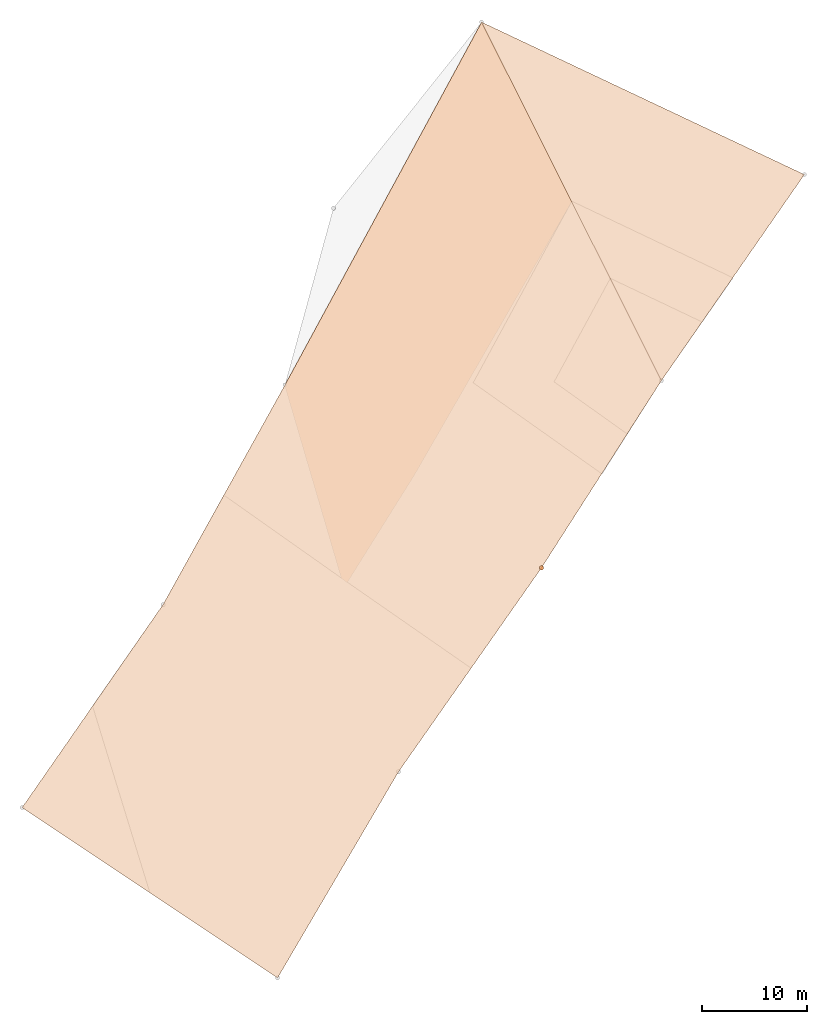
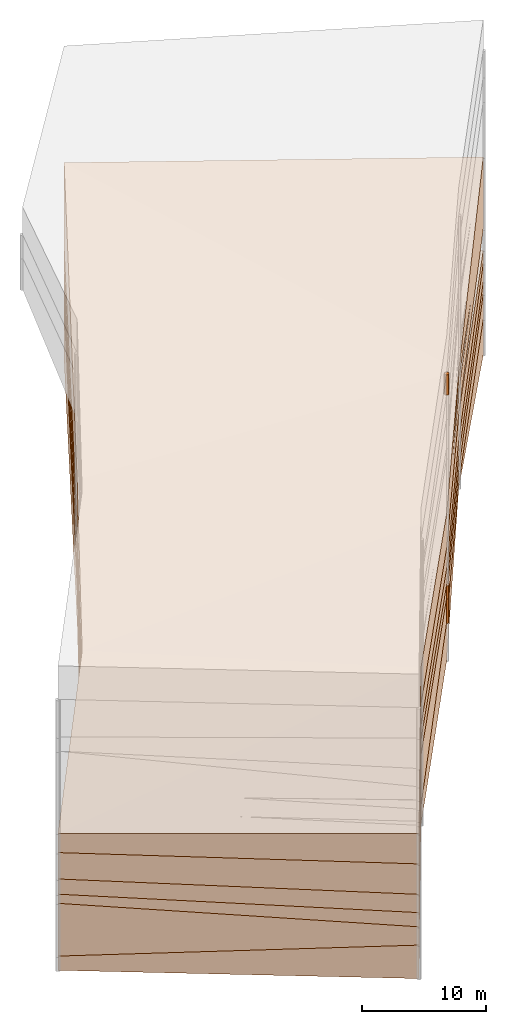
# One storey, part 12 of 24: 9 geographic elements.
"""IFC4 building model written with IfcOpenShell, lengths in metres."""

from ifc_helpers import new_model, entity, si_unit, converted_unit, frame, origin_with_axes, origin_2d_with_axis, place, context, subcontext, project, spatial, polygons, element, save


model = new_model("IFC4")

# Units and contexts
model_context = context("Model", 3, precision=1e-05, world=origin_with_axes())
plan_context = context("Plan", 2, precision=1e-05, world=origin_2d_with_axis())
body_context = subcontext(model_context, "Body", "Model", "MODEL_VIEW")
ifc_project = project(units=[converted_unit("PLANEANGLEUNIT", "degree", entity("IfcReal", 0.0174532925199433), si_unit("PLANEANGLEUNIT", "RADIAN"), dimensions=[0, 0, 0, 0, 0, 0, 0]), si_unit("AREAUNIT", "SQUARE_METRE"), si_unit("VOLUMEUNIT", "CUBIC_METRE"), si_unit("LENGTHUNIT", "METRE")], contexts=[model_context, plan_context])

# Site, building, storey
site_placement = place(None, origin_with_axes())
site = spatial("IfcSite", under=ifc_project, at=site_placement)
building_placement = place(site_placement, origin_with_axes())
building = spatial("IfcBuilding", under=site, at=building_placement, Name="Building")
storey_placement = place(building_placement, origin_with_axes())
storey = spatial("IfcBuildingStorey", under=building, at=storey_placement, Name="Storey")

# Geographic elements
geographic_element_1_placement = place(storey_placement, frame((7.95133209228516, 42.8018035888672, 0.786202132701874), z_axis=(0.0, 0.0, 1.0), x_axis=(0.830287629604424, -0.557335134480025, 0.0)))
element("IfcGeographicElement", 1, at=geographic_element_1_placement, inside=storey, PredefinedType="NOTDEFINED", context=body_context, shape_type="Tessellation", body=[
    polygons([(-17.3011207580566, 46.3160743713379, -1.78619968891144), (16.2700653076172, 51.3870964050293, -1.88620126247406), (16.2700634002686, 51.3870964050293, 5.21379899978638), (17.2530536651611, -39.969367980957, -0.586199462413788), (15.8775949478149, -17.2863731384277, -0.78620308637619), (17.2530498504639, -39.9693641662598, 2.41380023956299), (-11.9517650604248, -40.0619468688965, -0.786202311515808), (-11.9517660140991, -40.0619468688965, 1.11379766464233), (-11.5824747085571, -16.5691032409668, -0.686202526092529), (15.877592086792, -17.2863731384277, 2.81379675865173), (16.3572044372559, 6.40096139907837, 1.51979982852936), (-11.5824756622314, -16.5691032409668, 2.71379733085632), (16.3572044372559, 6.40096235275269, -1.88020026683807), (-13.599440574646, 7.2489914894104, -1.5772031545639), (15.9019184112549, 27.5337047576904, -3.48620200157166), (15.9019212722778, 27.5336990356445, 0.813797891139984), (15.901930809021, 27.5332012176514, -1.28617215156555), (16.128360748291, 17.0230274200439, -0.656133651733398), (16.1270484924316, 17.0840301513672, -0.656139612197876), (-13.5994424819946, 7.24899053573608, 2.82079696655273), (-17.3011226654053, 46.3160820007324, 6.61379957199097), (16.0857696533203, 39.4459991455078, -0.636202096939087), (15.9019355773926, 27.5346412658691, 0.0137467021122575), (15.901930809021, 27.5343894958496, -1.28616452217102), (15.9019174575806, 27.5337009429932, 0.0137979974970222), (15.9019174575806, 27.5337009429932, -1.28620207309723), (15.9019355773926, 27.5330333709717, 0.0137553941458464), (1.15123677253723, 17.3913478851318, -0.636202096939087), (-0.685844838619232, 36.9582176208496, -0.636202096939087)], [[[4, 8, 7]], [[12, 20, 14, 9]], [[8, 12, 9, 7]], [[24, 26, 25, 23]], [[11, 12, 10]], [[17, 28, 19]], [[8, 10, 12]], [[20, 1, 14]], [[11, 5, 13]], [[15, 16, 17]], [[18, 15, 19]], [[21, 16, 3]], [[16, 20, 11]], [[1, 3, 2]], [[25, 29, 23]], [[1, 2, 15]], [[2, 22, 15]], [[16, 15, 24]], [[16, 24, 23]], [[5, 7, 9]], [[13, 9, 14]], [[15, 14, 1]], [[28, 25, 27]], [[29, 22, 23]], [[29, 26, 24]], [[29, 24, 22]], [[26, 17, 27, 25]], [[17, 16, 27]], [[16, 18, 27]], [[16, 11, 18]], [[18, 11, 13]], [[15, 18, 13]], [[17, 19, 15]], [[22, 24, 15]], [[3, 22, 2]], [[3, 16, 22]], [[22, 16, 23]], [[26, 29, 17]], [[19, 28, 18]], [[28, 27, 18]], [[6, 5, 10]], [[4, 6, 8]], [[11, 20, 12]], [[17, 29, 28]], [[8, 6, 10]], [[20, 21, 1]], [[11, 10, 5]], [[21, 20, 16]], [[1, 21, 3]], [[25, 28, 29]], [[5, 4, 7]], [[13, 5, 9]], [[15, 13, 14]], [[6, 4, 5]]]),
])
geographic_element_2_placement = place(storey_placement, frame((22.7823867797852, 60.1952819824219, -5.6460132598877), z_axis=(0.0, 0.0, 1.0), x_axis=(0.867209961126124, -0.497942650637226, 0.0)))
element("IfcGeographicElement", 2, at=geographic_element_2_placement, inside=storey, PredefinedType="NOTDEFINED", context=body_context, shape_type="Tessellation", body=[
    polygons([(-18.2224273681641, 24.9432010650635, -1.05398368835449), (15.6210842132568, 27.65549659729, -1.8539856672287), (15.6210823059082, 27.65549659729, -0.653985977172852), (10.2166843414307, -63.5462646484375, -0.353983849287033), (10.4299249649048, -40.8226127624512, 0.646012187004089), (10.4299240112305, -40.8226089477539, 2.14601230621338), (10.2166843414307, -63.5462646484375, 1.04601562023163), (-18.9231872558594, -61.5974655151367, 0.646013259887695), (-16.9128646850586, -38.1878852844238, 0.546012759208679), (-18.9231872558594, -61.597469329834, 1.54601275920868), (13.586706161499, 3.88616228103638, -1.15398633480072), (-18.2224292755127, 24.9432048797607, 0.546015799045563), (-17.2602348327637, -14.2870655059814, 0.159011766314507), (12.5638914108276, -17.2267208099365, 0.952014684677124), (-16.9128665924072, -38.1878852844238, 2.04601263999939), (-17.260232925415, -14.2870674133301, -1.34398889541626), (13.5867052078247, 3.88616251945496, -2.5539870262146), (12.563892364502, -17.2267189025879, -0.34798526763916)], [[[14, 6, 5, 18]], [[10, 6, 15]], [[1, 12, 3, 2]], [[15, 14, 13]], [[5, 8, 9]], [[15, 13, 16, 9]], [[13, 11, 12]], [[1, 17, 16]], [[7, 5, 6]], [[11, 2, 3]], [[9, 18, 5]], [[7, 8, 4]], [[10, 9, 8]], [[18, 11, 14]], [[13, 1, 16]], [[10, 7, 6]], [[15, 6, 14]], [[5, 4, 8]], [[13, 14, 11]], [[1, 2, 17]], [[7, 4, 5]], [[11, 17, 2]], [[9, 16, 18]], [[7, 10, 8]], [[10, 15, 9]], [[18, 17, 11]], [[13, 12, 1]]]),
])
geographic_element_3_placement = place(storey_placement, frame((10.1280975341797, 43.8058166503906, -1.91961908340454), z_axis=(0.0, 0.0, 1.0), x_axis=(0.762361207972851, -0.647151750811335, 0.0)))
element("IfcGeographicElement", 3, at=geographic_element_3_placement, inside=storey, PredefinedType="NOTDEFINED", context=body_context, shape_type="Tessellation", body=[
    polygons([(-23.4085464477539, 41.9031105041504, -3.18037819862366), (9.37964344024658, 50.716423034668, -4.38037967681885), (9.37964057922363, 50.716423034668, -2.58037996292114), (20.627742767334, -39.950267791748, -2.68037819862366), (16.7107181549072, -17.5657424926758, -1.58038175106049), (16.7107181549072, -17.565746307373, -0.180381760001183), (20.627742767334, -39.950267791748, -0.880378186702728), (-8.38149642944336, -43.3258018493652, -2.18038105964661), (-10.6558847427368, -19.9403991699219, -1.68038141727448), (-8.38149452209473, -43.3258056640625, -0.680381059646606), (11.695707321167, 26.97287940979, -3.38038039207458), (14.5240888595581, 6.02532434463501, -1.17437899112701), (-10.6558799743652, -19.9404010772705, 0.119618646800518), (-15.337963104248, 3.49990677833557, -3.56738209724426), (14.5240879058838, 6.02532434463501, -2.77437925338745), (-15.3379621505737, 3.49990725517273, -0.969382345676422), (11.6957035064697, 26.97287940979, -4.88038015365601), (-23.4085426330566, 41.9031028747559, -1.38037848472595)], [[[6, 7, 4, 5]], [[10, 6, 13]], [[11, 2, 3]], [[13, 12, 16]], [[12, 6, 5, 15]], [[16, 12, 11]], [[16, 9, 13]], [[14, 17, 15]], [[15, 11, 12]], [[5, 8, 9]], [[1, 3, 2]], [[15, 9, 14]], [[17, 14, 1]], [[18, 11, 3]], [[11, 18, 16]], [[7, 8, 4]], [[10, 9, 8]], [[18, 14, 16]], [[10, 7, 6]], [[11, 17, 2]], [[13, 6, 12]], [[16, 14, 9]], [[15, 17, 11]], [[5, 4, 8]], [[1, 18, 3]], [[15, 5, 9]], [[7, 10, 8]], [[10, 13, 9]], [[18, 1, 14]]]),
])
geographic_element_4_placement = place(storey_placement, frame((10.1280975341797, 43.8058166503906, -1.91961908340454), z_axis=(0.0, 0.0, 1.0), x_axis=(0.836836988464579, -0.547452148354114, 0.0)))
element("IfcGeographicElement", 4, at=geographic_element_4_placement, inside=storey, PredefinedType="NOTDEFINED", context=body_context, shape_type="Tessellation", body=[
    polygons([(-18.022741317749, 44.4860763549805, -1.38037836551666), (15.6062059402466, 49.1587181091309, -2.58037996292114), (15.6062097549438, 49.1587219238281, -1.28037989139557), (15.5060205459595, -42.2029724121094, -0.880378186702728), (14.3995838165283, -19.5052700042725, -0.180381760001183), (14.3995847702026, -19.5052719116211, 1.91961801052094), (15.5060224533081, -42.2029762268066, 2.11962151527405), (-13.6978406906128, -41.9493026733398, -0.680381059646606), (-13.0500526428223, -18.4624881744385, 0.119618646800518), (-13.6978397369385, -41.9493026733398, 1.91961872577667), (14.9552879333496, 25.3113651275635, -0.78038078546524), (-18.0227375030518, 44.4860725402832, 0.919621407985687), (15.1599960327148, 4.17471504211426, 0.825620830059052), (-14.7844924926758, 5.37784433364868, 1.12861788272858), (-13.0500516891479, -18.4624881744385, 2.01961874961853), (14.9552879333496, 25.3113651275635, -3.38038039207458), (-14.7844915390015, 5.37784481048584, -0.969382226467133), (15.1599969863892, 4.17471504211426, -1.17437899112701)], [[[10, 6, 15]], [[11, 2, 3]], [[12, 17, 14]], [[1, 3, 2]], [[9, 18, 5]], [[16, 1, 2]], [[14, 13, 11]], [[11, 13, 18, 16]], [[17, 16, 18]], [[14, 17, 9, 15]], [[12, 11, 3]], [[5, 8, 9]], [[6, 7, 4, 5]], [[13, 5, 18]], [[10, 15, 9, 8]], [[15, 13, 14]], [[10, 4, 7]], [[10, 7, 6]], [[11, 16, 2]], [[12, 1, 17]], [[1, 12, 3]], [[9, 17, 18]], [[16, 17, 1]], [[12, 14, 11]], [[5, 4, 8]], [[13, 6, 5]], [[15, 6, 13]], [[10, 8, 4]]]),
])
geographic_element_5_placement = place(storey_placement, frame((25.6226844787598, 67.0861511230469, -8.31018447875977), z_axis=(0.0, 0.0, 1.0), x_axis=(0.826104281963329, -0.563517271538196, 0.0)))
element("IfcGeographicElement", 5, at=geographic_element_5_placement, inside=storey, PredefinedType="NOTDEFINED", context=body_context, shape_type="Tessellation", body=[
    polygons([(-18.5601062774658, 16.1661338806152, 1.610187292099), (14.9722986221313, 21.4876003265381, -1.68981444835663), (16.6371936798096, -69.8589859008789, 0.510187566280365), (15.0924549102783, -47.1868858337402, -1.68981659412384), (15.0924558639526, -47.1868858337402, 3.31018328666687), (16.6371936798096, -69.8589782714844, 2.31018733978271), (-12.5661153793335, -70.169563293457, -1.88981521129608), (-12.5661172866821, -70.169563293457, 3.31018424034119), (-12.3722009658813, -46.6746139526367, -0.589816212654114), (15.3952388763428, -23.4966297149658, 2.31618595123291), (-12.3722019195557, -46.6746139526367, 3.21018362045288), (15.3952388763428, -23.4966297149658, -0.0838150903582573), (-14.5669059753418, -22.8722343444824, 1.32018172740936), (14.7822170257568, -2.36787891387939, 0.110183626413345), (14.7822170257568, -2.36787915229797, -1.18981528282166), (14.9722967147827, 21.4875984191895, 0.810185372829437)], [[[8, 5, 11]], [[9, 12, 4]], [[14, 10, 12, 15]], [[4, 7, 9]], [[3, 8, 7]], [[10, 5, 4, 12]], [[11, 10, 13]], [[13, 15, 12]], [[13, 10, 14]], [[8, 9, 7]], [[1, 13, 14]], [[15, 13, 1]], [[2, 1, 16]], [[5, 6, 3, 4]], [[11, 13, 9]], [[14, 2, 16]], [[8, 6, 5]], [[9, 13, 12]], [[4, 3, 7]], [[3, 6, 8]], [[11, 5, 10]], [[8, 11, 9]], [[14, 15, 2]]]),
])
geographic_element_6_placement = place(storey_placement, frame((0.941490471363068, 18.3487815856934, 0.146752789616585), z_axis=(1.20677100312604e-07, 2.68795723457058e-08, 0.999999999999992), x_axis=(0.843925976962061, -0.536459640055637, -8.74227364323347e-08)))
element("IfcGeographicElement", 6, at=geographic_element_6_placement, inside=storey, PredefinedType="NOTDEFINED", context=body_context, shape_type="Tessellation", body=[
    polygons([(-23.3431797027588, 71.1300964355469, -12.2467432022095), (-23.3431797027588, 71.1300964355469, -6.84674501419067), (10.3440017700195, 75.3624801635742, -13.6467428207397), (10.3440074920654, 75.3624801635742, -10.1467428207397), (9.04883098602295, -15.9900808334351, -11.2467489242554), (8.23937225341797, 6.72014999389648, -12.0467510223389), (8.23937225341797, 6.72014999389648, -10.1467523574829), (9.04883003234863, -15.9900817871094, -7.94675016403198), (-20.1492080688477, -15.3544483184814, -11.746753692627), (-20.1492080688477, -15.3544464111328, -10.346755027771), (-19.1942710876465, 8.12187671661377, -12.1467542648315), (9.38122081756592, 51.5256767272949, -10.1467456817627), (-19.1942710876465, 8.12187576293945, -9.0467529296875), (-20.6167411804199, 31.9828605651855, -10.7367534637451), (9.30944919586182, 30.388162612915, -8.54074668884277), (-20.6167449951172, 31.9828586578369, -7.13675355911255), (9.30944919586182, 30.3881607055664, -12.3407459259033), (9.38122272491455, 51.5256767272949, -9.6467456817627)], [[[13, 14, 11]], [[13, 15, 16]], [[6, 9, 11]], [[7, 8, 5, 6]], [[1, 12, 14]], [[17, 11, 14]], [[10, 13, 11, 9]], [[15, 12, 18]], [[16, 15, 18]], [[4, 12, 3]], [[15, 7, 6, 17]], [[1, 4, 3]], [[10, 7, 13]], [[5, 10, 9]], [[2, 16, 18]], [[14, 12, 17]], [[2, 14, 16]], [[13, 16, 14]], [[13, 7, 15]], [[6, 5, 9]], [[1, 3, 12]], [[17, 6, 11]], [[15, 17, 12]], [[4, 18, 12]], [[1, 2, 4]], [[10, 8, 7]], [[5, 8, 10]], [[2, 1, 14]]]),
])
geographic_element_7_placement = place(storey_placement, frame((25.1000003814697, 39.0, 15.1000003814697), z_axis=(0.0, 0.0, 1.0), x_axis=(1.0, 0.0, 0.0)))
element("IfcGeographicElement", 7, at=geographic_element_7_placement, inside=storey, PredefinedType="NOTDEFINED", context=body_context, shape_type="Tessellation", body=[
    polygons([(0.0, 0.0, -1.00000023841858), (0.0390180610120296, 0.196157038211823, -1.00000023841858), (0.0, 0.199999988079071, -1.00000023841858), (0.0, 0.0, 1.00000023841858), (0.0, 0.199999988079071, 1.00000023841858), (0.0390180610120296, 0.196157038211823, 1.00000023841858), (0.0765366926789284, 0.18477588891983, -1.00000023841858), (0.0765366926789284, 0.18477588891983, 1.00000023841858), (0.111114047467709, 0.166293919086456, -1.00000023841858), (0.111114047467709, 0.166293919086456, 1.00000023841858), (0.141421362757683, 0.141421362757683, -1.00000023841858), (0.141421362757683, 0.141421362757683, 1.00000023841858), (0.166293919086456, 0.111114047467709, -1.00000023841858), (0.166293919086456, 0.111114047467709, 1.00000023841858), (0.18477588891983, 0.0765366926789284, -1.00000023841858), (0.18477588891983, 0.0765366926789284, 1.00000023841858), (0.196157038211823, 0.0390180610120296, -1.00000023841858), (0.196157038211823, 0.0390180610120296, 1.00000023841858), (0.199999988079071, 0.0, -1.00000023841858), (0.199999988079071, 0.0, 1.00000023841858), (0.196157038211823, -0.0390180610120296, -1.00000023841858), (0.196157038211823, -0.0390180610120296, 1.00000023841858), (0.18477588891983, -0.0765366926789284, -1.00000023841858), (0.18477588891983, -0.0765366926789284, 1.00000023841858), (0.166293919086456, -0.111114047467709, -1.00000023841858), (0.166293919086456, -0.111114047467709, 1.00000023841858), (0.141421362757683, -0.141421362757683, -1.00000023841858), (0.141421362757683, -0.141421362757683, 1.00000023841858), (0.111114047467709, -0.166293919086456, -1.00000023841858), (0.111114047467709, -0.166293919086456, 1.00000023841858), (0.0765366926789284, -0.18477588891983, -1.00000023841858), (0.0765366926789284, -0.18477588891983, 1.00000023841858), (0.0390180610120296, -0.196157038211823, -1.00000023841858), (0.0390180610120296, -0.196157038211823, 1.00000023841858), (0.0, -0.199999988079071, -1.00000023841858), (0.0, -0.199999988079071, 1.00000023841858), (-0.0390180610120296, -0.196157038211823, -1.00000023841858), (-0.0390180610120296, -0.196157038211823, 1.00000023841858), (-0.0765366926789284, -0.18477588891983, -1.00000023841858), (-0.0765366926789284, -0.18477588891983, 1.00000023841858), (-0.111114047467709, -0.166293919086456, -1.00000023841858), (-0.111114047467709, -0.166293919086456, 1.00000023841858), (-0.141421362757683, -0.141421362757683, -1.00000023841858), (-0.141421362757683, -0.141421362757683, 1.00000023841858), (-0.166293919086456, -0.111114047467709, -1.00000023841858), (-0.166293919086456, -0.111114047467709, 1.00000023841858), (-0.18477588891983, -0.0765366926789284, -1.00000023841858), (-0.18477588891983, -0.0765366926789284, 1.00000023841858), (-0.196157038211823, -0.0390180610120296, -1.00000023841858), (-0.196157038211823, -0.0390180610120296, 1.00000023841858), (-0.199999988079071, 0.0, -1.00000023841858), (-0.199999988079071, 0.0, 1.00000023841858), (-0.196157038211823, 0.0390180610120296, -1.00000023841858), (-0.196157038211823, 0.0390180610120296, 1.00000023841858), (-0.18477588891983, 0.0765366926789284, -1.00000023841858), (-0.18477588891983, 0.0765366926789284, 1.00000023841858), (-0.166293919086456, 0.111114047467709, -1.00000023841858), (-0.166293919086456, 0.111114047467709, 1.00000023841858), (-0.141421362757683, 0.141421362757683, -1.00000023841858), (-0.141421362757683, 0.141421362757683, 1.00000023841858), (-0.111114047467709, 0.166293919086456, -1.00000023841858), (-0.111114047467709, 0.166293919086456, 1.00000023841858), (-0.0765366926789284, 0.18477588891983, -1.00000023841858), (-0.0765366926789284, 0.18477588891983, 1.00000023841858), (-0.0390180610120296, 0.196157038211823, -1.00000023841858), (-0.0390180610120296, 0.196157038211823, 1.00000023841858)], [[[3, 2, 1]], [[6, 5, 4]], [[28, 30, 29, 27]], [[2, 7, 1]], [[8, 6, 4]], [[42, 44, 43, 41]], [[7, 9, 1]], [[10, 8, 4]], [[10, 12, 11, 9]], [[9, 11, 1]], [[12, 10, 4]], [[11, 13, 1]], [[12, 4, 14]], [[46, 48, 47, 45]], [[1, 13, 15]], [[14, 4, 16]], [[34, 36, 35, 33]], [[1, 15, 17]], [[4, 18, 16]], [[54, 56, 55, 53]], [[1, 17, 19]], [[4, 20, 18]], [[16, 18, 17, 15]], [[1, 19, 21]], [[20, 4, 22]], [[18, 20, 19, 17]], [[1, 21, 23]], [[4, 24, 22]], [[20, 22, 21, 19]], [[1, 23, 25]], [[24, 4, 26]], [[58, 60, 59, 57]], [[1, 25, 27]], [[26, 4, 28]], [[24, 26, 25, 23]], [[1, 27, 29]], [[28, 4, 30]], [[26, 28, 27, 25]], [[1, 29, 31]], [[4, 32, 30]], [[5, 6, 2, 3]], [[1, 31, 33]], [[4, 34, 32]], [[64, 66, 65, 63]], [[1, 33, 35]], [[4, 36, 34]], [[8, 10, 9, 7]], [[1, 35, 37]], [[4, 38, 36]], [[32, 34, 33, 31]], [[1, 37, 39]], [[4, 40, 38]], [[36, 38, 37, 35]], [[1, 39, 41]], [[4, 42, 40]], [[38, 40, 39, 37]], [[43, 1, 41]], [[4, 44, 42]], [[40, 42, 41, 39]], [[45, 1, 43]], [[4, 46, 44]], [[6, 8, 7, 2]], [[47, 1, 45]], [[4, 48, 46]], [[66, 5, 3, 65]], [[47, 49, 1]], [[50, 48, 4]], [[50, 52, 51, 49]], [[51, 1, 49]], [[52, 50, 4]], [[14, 16, 15, 13]], [[51, 53, 1]], [[4, 54, 52]], [[48, 50, 49, 47]], [[53, 55, 1]], [[56, 54, 4]], [[52, 54, 53, 51]], [[57, 1, 55]], [[4, 58, 56]], [[22, 24, 23, 21]], [[59, 1, 57]], [[60, 58, 4]], [[56, 58, 57, 55]], [[59, 61, 1]], [[62, 60, 4]], [[30, 32, 31, 29]], [[61, 63, 1]], [[64, 62, 4]], [[60, 62, 61, 59]], [[63, 65, 1]], [[66, 64, 4]], [[62, 64, 63, 61]], [[65, 3, 1]], [[5, 66, 4]], [[44, 46, 45, 43]], [[12, 14, 13, 11]]]),
])
geographic_element_8_placement = place(storey_placement, frame((25.1000003814697, 39.0, -7.19399881362915), z_axis=(0.0, 0.0, 1.0), x_axis=(1.0, 0.0, 0.0)))
element("IfcGeographicElement", 8, at=geographic_element_8_placement, inside=storey, PredefinedType="NOTDEFINED", context=body_context, shape_type="Tessellation", body=[
    polygons([(0.0, 0.0, -1.20000004768372), (0.0390180610120296, 0.196157038211823, -1.20000004768372), (0.0, 0.199999988079071, -1.20000004768372), (0.0, 0.0, 1.20000004768372), (0.0, 0.199999988079071, 1.20000004768372), (0.0390180610120296, 0.196157038211823, 1.20000004768372), (0.0765366926789284, 0.18477588891983, -1.20000004768372), (0.0765366926789284, 0.18477588891983, 1.20000004768372), (0.111114047467709, 0.166293919086456, -1.20000004768372), (0.111114047467709, 0.166293919086456, 1.20000004768372), (0.141421362757683, 0.141421362757683, -1.20000004768372), (0.141421362757683, 0.141421362757683, 1.20000004768372), (0.166293919086456, 0.111114047467709, -1.20000004768372), (0.166293919086456, 0.111114047467709, 1.20000004768372), (0.18477588891983, 0.0765366926789284, -1.20000004768372), (0.18477588891983, 0.0765366926789284, 1.20000004768372), (0.196157038211823, 0.0390180610120296, -1.20000004768372), (0.196157038211823, 0.0390180610120296, 1.20000004768372), (0.199999988079071, 0.0, -1.20000004768372), (0.199999988079071, 0.0, 1.20000004768372), (0.196157038211823, -0.0390180610120296, -1.20000004768372), (0.196157038211823, -0.0390180610120296, 1.20000004768372), (0.18477588891983, -0.0765366926789284, -1.20000004768372), (0.18477588891983, -0.0765366926789284, 1.20000004768372), (0.166293919086456, -0.111114047467709, -1.20000004768372), (0.166293919086456, -0.111114047467709, 1.20000004768372), (0.141421362757683, -0.141421362757683, -1.20000004768372), (0.141421362757683, -0.141421362757683, 1.20000004768372), (0.111114047467709, -0.166293919086456, -1.20000004768372), (0.111114047467709, -0.166293919086456, 1.20000004768372), (0.0765366926789284, -0.18477588891983, -1.20000004768372), (0.0765366926789284, -0.18477588891983, 1.20000004768372), (0.0390180610120296, -0.196157038211823, -1.20000004768372), (0.0390180610120296, -0.196157038211823, 1.20000004768372), (0.0, -0.199999988079071, -1.20000004768372), (0.0, -0.199999988079071, 1.20000004768372), (-0.0390180610120296, -0.196157038211823, -1.20000004768372), (-0.0390180610120296, -0.196157038211823, 1.20000004768372), (-0.0765366926789284, -0.18477588891983, -1.20000004768372), (-0.0765366926789284, -0.18477588891983, 1.20000004768372), (-0.111114047467709, -0.166293919086456, -1.20000004768372), (-0.111114047467709, -0.166293919086456, 1.20000004768372), (-0.141421362757683, -0.141421362757683, -1.20000004768372), (-0.141421362757683, -0.141421362757683, 1.20000004768372), (-0.166293919086456, -0.111114047467709, -1.20000004768372), (-0.166293919086456, -0.111114047467709, 1.20000004768372), (-0.18477588891983, -0.0765366926789284, -1.20000004768372), (-0.18477588891983, -0.0765366926789284, 1.20000004768372), (-0.196157038211823, -0.0390180610120296, -1.20000004768372), (-0.196157038211823, -0.0390180610120296, 1.20000004768372), (-0.199999988079071, 0.0, -1.20000004768372), (-0.199999988079071, 0.0, 1.20000004768372), (-0.196157038211823, 0.0390180610120296, -1.20000004768372), (-0.196157038211823, 0.0390180610120296, 1.20000004768372), (-0.18477588891983, 0.0765366926789284, -1.20000004768372), (-0.18477588891983, 0.0765366926789284, 1.20000004768372), (-0.166293919086456, 0.111114047467709, -1.20000004768372), (-0.166293919086456, 0.111114047467709, 1.20000004768372), (-0.141421362757683, 0.141421362757683, -1.20000004768372), (-0.141421362757683, 0.141421362757683, 1.20000004768372), (-0.111114047467709, 0.166293919086456, -1.20000004768372), (-0.111114047467709, 0.166293919086456, 1.20000004768372), (-0.0765366926789284, 0.18477588891983, -1.20000004768372), (-0.0765366926789284, 0.18477588891983, 1.20000004768372), (-0.0390180610120296, 0.196157038211823, -1.20000004768372), (-0.0390180610120296, 0.196157038211823, 1.20000004768372)], [[[3, 2, 1]], [[6, 5, 4]], [[28, 30, 29, 27]], [[2, 7, 1]], [[8, 6, 4]], [[36, 38, 37, 35]], [[7, 9, 1]], [[10, 8, 4]], [[56, 58, 57, 55]], [[9, 11, 1]], [[12, 10, 4]], [[58, 60, 59, 57]], [[11, 13, 1]], [[12, 4, 14]], [[54, 56, 55, 53]], [[1, 13, 15]], [[14, 4, 16]], [[10, 12, 11, 9]], [[1, 15, 17]], [[16, 4, 18]], [[60, 62, 61, 59]], [[1, 17, 19]], [[18, 4, 20]], [[16, 18, 17, 15]], [[1, 19, 21]], [[20, 4, 22]], [[18, 20, 19, 17]], [[1, 21, 23]], [[22, 4, 24]], [[20, 22, 21, 19]], [[1, 23, 25]], [[24, 4, 26]], [[22, 24, 23, 21]], [[27, 1, 25]], [[26, 4, 28]], [[24, 26, 25, 23]], [[1, 27, 29]], [[28, 4, 30]], [[62, 64, 63, 61]], [[1, 29, 31]], [[4, 32, 30]], [[64, 66, 65, 63]], [[1, 31, 33]], [[4, 34, 32]], [[30, 32, 31, 29]], [[1, 33, 35]], [[4, 36, 34]], [[8, 10, 9, 7]], [[1, 35, 37]], [[4, 38, 36]], [[32, 34, 33, 31]], [[1, 37, 39]], [[4, 40, 38]], [[6, 8, 7, 2]], [[1, 39, 41]], [[4, 42, 40]], [[38, 40, 39, 37]], [[43, 1, 41]], [[4, 44, 42]], [[40, 42, 41, 39]], [[45, 1, 43]], [[46, 44, 4]], [[42, 44, 43, 41]], [[47, 1, 45]], [[4, 48, 46]], [[44, 46, 45, 43]], [[49, 1, 47]], [[4, 50, 48]], [[46, 48, 47, 45]], [[51, 1, 49]], [[4, 52, 50]], [[48, 50, 49, 47]], [[53, 1, 51]], [[4, 54, 52]], [[66, 5, 3, 65]], [[55, 1, 53]], [[4, 56, 54]], [[52, 54, 53, 51]], [[57, 1, 55]], [[4, 58, 56]], [[57, 59, 1]], [[60, 58, 4]], [[34, 36, 35, 33]], [[59, 61, 1]], [[62, 60, 4]], [[14, 16, 15, 13]], [[61, 63, 1]], [[64, 62, 4]], [[26, 28, 27, 25]], [[63, 65, 1]], [[66, 64, 4]], [[5, 6, 2, 3]], [[65, 3, 1]], [[5, 66, 4]], [[50, 52, 51, 49]], [[12, 14, 13, 11]]]),
])
geographic_element_9_placement = place(storey_placement, frame((25.1000003814697, 39.0, -5.34399843215942), z_axis=(0.0, 0.0, 1.0), x_axis=(1.0, 0.0, 0.0)))
element("IfcGeographicElement", 9, at=geographic_element_9_placement, inside=storey, PredefinedType="NOTDEFINED", context=body_context, shape_type="Tessellation", body=[
    polygons([(0.0, 0.0, -0.649999916553497), (0.0390180610120296, 0.196157038211823, -0.649999916553497), (0.0, 0.199999988079071, -0.649999916553497), (0.0, 0.0, 0.649999916553497), (0.0, 0.199999988079071, 0.649999916553497), (0.0390180610120296, 0.196157038211823, 0.649999916553497), (0.0765366926789284, 0.18477588891983, -0.649999916553497), (0.0765366926789284, 0.18477588891983, 0.649999916553497), (0.111114047467709, 0.166293919086456, -0.649999916553497), (0.111114047467709, 0.166293919086456, 0.649999916553497), (0.141421362757683, 0.141421362757683, -0.649999916553497), (0.141421362757683, 0.141421362757683, 0.649999916553497), (0.166293919086456, 0.111114047467709, -0.649999916553497), (0.166293919086456, 0.111114047467709, 0.649999916553497), (0.18477588891983, 0.0765366926789284, -0.649999916553497), (0.18477588891983, 0.0765366926789284, 0.649999916553497), (0.196157038211823, 0.0390180610120296, -0.649999916553497), (0.196157038211823, 0.0390180610120296, 0.649999916553497), (0.199999988079071, 0.0, -0.649999916553497), (0.199999988079071, 0.0, 0.649999916553497), (0.196157038211823, -0.0390180610120296, -0.649999916553497), (0.196157038211823, -0.0390180610120296, 0.649999916553497), (0.18477588891983, -0.0765366926789284, -0.649999916553497), (0.18477588891983, -0.0765366926789284, 0.649999916553497), (0.166293919086456, -0.111114047467709, -0.649999916553497), (0.166293919086456, -0.111114047467709, 0.649999916553497), (0.141421362757683, -0.141421362757683, -0.649999916553497), (0.141421362757683, -0.141421362757683, 0.649999916553497), (0.111114047467709, -0.166293919086456, -0.649999916553497), (0.111114047467709, -0.166293919086456, 0.649999916553497), (0.0765366926789284, -0.18477588891983, -0.649999916553497), (0.0765366926789284, -0.18477588891983, 0.649999916553497), (0.0390180610120296, -0.196157038211823, -0.649999916553497), (0.0390180610120296, -0.196157038211823, 0.649999916553497), (0.0, -0.199999988079071, -0.649999916553497), (0.0, -0.199999988079071, 0.649999916553497), (-0.0390180610120296, -0.196157038211823, -0.649999916553497), (-0.0390180610120296, -0.196157038211823, 0.649999916553497), (-0.0765366926789284, -0.18477588891983, -0.649999916553497), (-0.0765366926789284, -0.18477588891983, 0.649999916553497), (-0.111114047467709, -0.166293919086456, -0.649999916553497), (-0.111114047467709, -0.166293919086456, 0.649999916553497), (-0.141421362757683, -0.141421362757683, -0.649999916553497), (-0.141421362757683, -0.141421362757683, 0.649999916553497), (-0.166293919086456, -0.111114047467709, -0.649999916553497), (-0.166293919086456, -0.111114047467709, 0.649999916553497), (-0.18477588891983, -0.0765366926789284, -0.649999916553497), (-0.18477588891983, -0.0765366926789284, 0.649999916553497), (-0.196157038211823, -0.0390180610120296, -0.649999916553497), (-0.196157038211823, -0.0390180610120296, 0.649999916553497), (-0.199999988079071, 0.0, -0.649999916553497), (-0.199999988079071, 0.0, 0.649999916553497), (-0.196157038211823, 0.0390180610120296, -0.649999916553497), (-0.196157038211823, 0.0390180610120296, 0.649999916553497), (-0.18477588891983, 0.0765366926789284, -0.649999916553497), (-0.18477588891983, 0.0765366926789284, 0.649999916553497), (-0.166293919086456, 0.111114047467709, -0.649999916553497), (-0.166293919086456, 0.111114047467709, 0.649999916553497), (-0.141421362757683, 0.141421362757683, -0.649999916553497), (-0.141421362757683, 0.141421362757683, 0.649999916553497), (-0.111114047467709, 0.166293919086456, -0.649999916553497), (-0.111114047467709, 0.166293919086456, 0.649999916553497), (-0.0765366926789284, 0.18477588891983, -0.649999916553497), (-0.0765366926789284, 0.18477588891983, 0.649999916553497), (-0.0390180610120296, 0.196157038211823, -0.649999916553497), (-0.0390180610120296, 0.196157038211823, 0.649999916553497)], [[[3, 2, 1]], [[6, 5, 4]], [[32, 34, 33, 31]], [[2, 7, 1]], [[8, 6, 4]], [[64, 66, 65, 63]], [[7, 9, 1]], [[10, 8, 4]], [[9, 11, 1]], [[12, 10, 4]], [[40, 42, 41, 39]], [[1, 11, 13]], [[12, 4, 14]], [[10, 12, 11, 9]], [[1, 13, 15]], [[4, 16, 14]], [[12, 14, 13, 11]], [[1, 15, 17]], [[4, 18, 16]], [[18, 20, 19, 17]], [[1, 17, 19]], [[4, 20, 18]], [[20, 22, 21, 19]], [[1, 19, 21]], [[4, 22, 20]], [[22, 24, 23, 21]], [[1, 21, 23]], [[22, 4, 24]], [[54, 56, 55, 53]], [[1, 23, 25]], [[24, 4, 26]], [[56, 58, 57, 55]], [[1, 25, 27]], [[4, 28, 26]], [[24, 26, 25, 23]], [[1, 27, 29]], [[28, 4, 30]], [[26, 28, 27, 25]], [[1, 29, 31]], [[4, 32, 30]], [[46, 48, 47, 45]], [[1, 31, 33]], [[4, 34, 32]], [[36, 38, 37, 35]], [[1, 33, 35]], [[4, 36, 34]], [[42, 44, 43, 41]], [[1, 35, 37]], [[4, 38, 36]], [[38, 40, 39, 37]], [[1, 37, 39]], [[4, 40, 38]], [[34, 36, 35, 33]], [[1, 39, 41]], [[4, 42, 40]], [[8, 10, 9, 7]], [[43, 1, 41]], [[4, 44, 42]], [[44, 46, 45, 43]], [[43, 45, 1]], [[4, 46, 44]], [[30, 32, 31, 29]], [[47, 1, 45]], [[48, 46, 4]], [[28, 30, 29, 27]], [[49, 1, 47]], [[50, 48, 4]], [[5, 6, 2, 3]], [[49, 51, 1]], [[52, 50, 4]], [[48, 50, 49, 47]], [[51, 53, 1]], [[54, 52, 4]], [[50, 52, 51, 49]], [[53, 55, 1]], [[4, 56, 54]], [[52, 54, 53, 51]], [[55, 57, 1]], [[4, 58, 56]], [[58, 60, 59, 57]], [[59, 1, 57]], [[60, 58, 4]], [[60, 62, 61, 59]], [[59, 61, 1]], [[62, 60, 4]], [[62, 64, 63, 61]], [[61, 63, 1]], [[64, 62, 4]], [[14, 16, 15, 13]], [[63, 65, 1]], [[66, 64, 4]], [[16, 18, 17, 15]], [[65, 3, 1]], [[5, 66, 4]], [[6, 8, 7, 2]], [[66, 5, 3, 65]]]),
])

save(model, "model.ifc")
